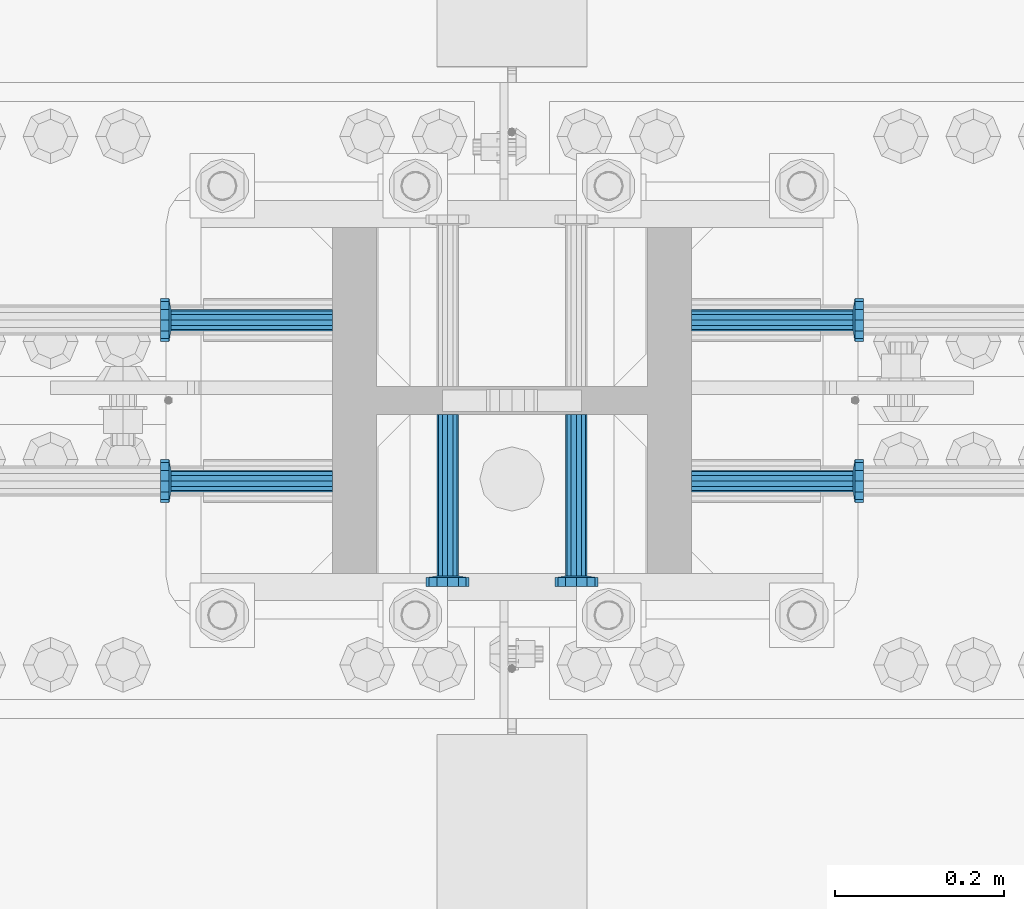
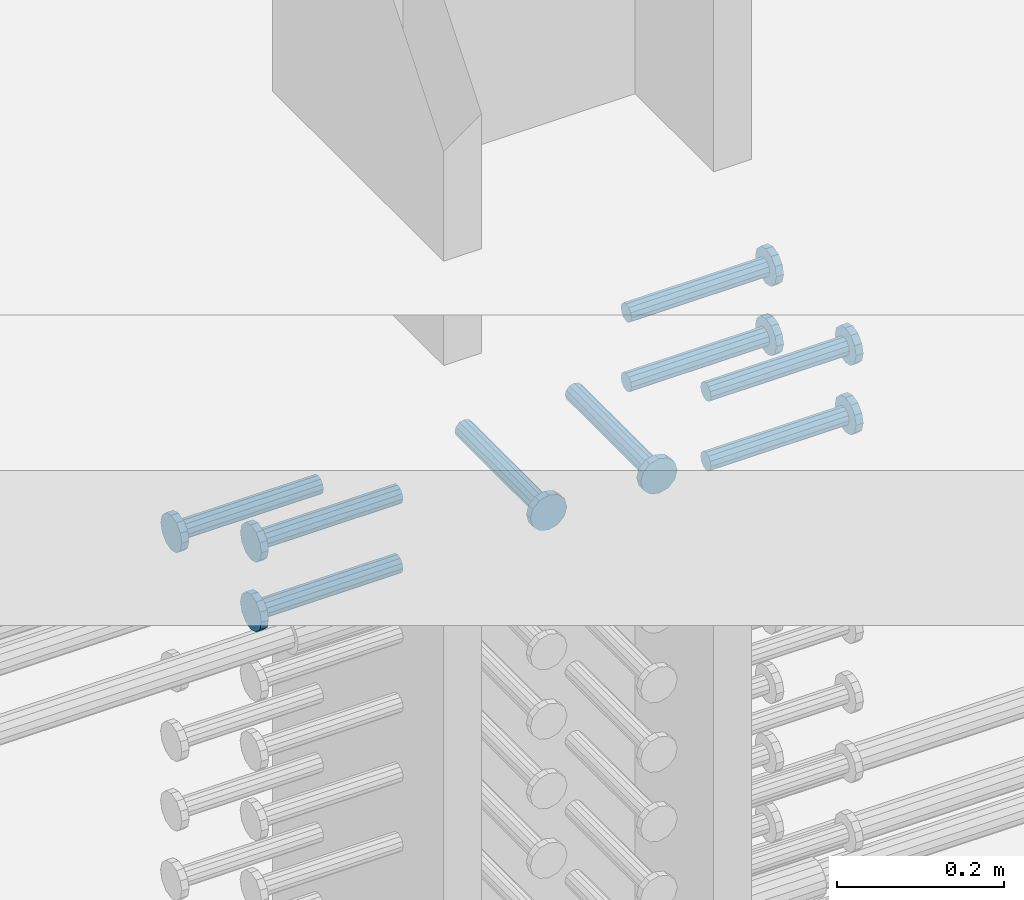
# One storey, part 1216 of 1763: 9 beams, 1 element without a shape of its own.
"""IFC2X3 building model written with IfcOpenShell, lengths in millimetres."""

from ifc_helpers import new_model, si_unit, frame, origin_with_axes, place, context, subcontext, project, spatial, faceted_brep, material, type_object, element, aggregate, save


model = new_model("IFC2X3")

# Units and contexts
model_context = context("Model", 3, precision=1e-05, world=origin_with_axes())
body_context = subcontext(model_context, "Body", "Model", "MODEL_VIEW")
ifc_project = project(units=[si_unit("LENGTHUNIT", "METRE", prefix="MILLI"), si_unit("AREAUNIT", "SQUARE_METRE"), si_unit("VOLUMEUNIT", "CUBIC_METRE"), si_unit("MASSUNIT", "GRAM", prefix="KILO"), si_unit("TIMEUNIT", "SECOND"), si_unit("PLANEANGLEUNIT", "RADIAN"), si_unit("SOLIDANGLEUNIT", "STERADIAN"), si_unit("THERMODYNAMICTEMPERATUREUNIT", "DEGREE_CELSIUS"), si_unit("LUMINOUSINTENSITYUNIT", "LUMEN")], contexts=[model_context])

# Site, building, storey
site_placement = place(None, origin_with_axes())
site = spatial("IfcSite", under=ifc_project, at=site_placement, CompositionType="ELEMENT")
building_placement = place(site_placement, origin_with_axes())
building = spatial("IfcBuilding", under=site, at=building_placement, Name="Undefined", CompositionType="ELEMENT")
storey_placement = place(building_placement, origin_with_axes())
storey = spatial("IfcBuildingStorey", under=building, at=storey_placement, Name="Undefined", CompositionType="ELEMENT", Elevation=0.0)

# Assembly, beams
assembly_placement = place(storey_placement, origin_with_axes())
assembly = element("IfcElementAssembly", 1, at=assembly_placement, inside=storey, Name="COLUMN", AssemblyPlace="NOTDEFINED", PredefinedType="RIGID_FRAME")
ifc_material = material(Name="STEEL/A108")
beam_type = type_object("IfcBeamType", PredefinedType="NOTDEFINED")
beam_1_placement = place(assembly_placement, frame((-61807.1623424341, 361.949999999998, 4927.60000000008), z_axis=(0.0, 1.0, 0.0), x_axis=(-1.0, 0.0, 0.0)))
beam_1 = element("IfcBeam", 2, at=beam_1_placement, type_object=beam_type, material=ifc_material, Name="HEADED STUD ANCHOR", context=body_context, shape_type="Brep", body=[
    faceted_brep([(0.0, -12.6999999999971, -1.81898940354586e-12), (3.63797880709171e-12, -11.0, -6.34999990463257), (191.00799999576, -11.0, -6.34999990454889), (191.007999995752, -12.6999998092651, 8.36735125631094e-11), (7.27595761418343e-12, -6.34999990463257, -11.0), (191.00799999576, -6.34999990463257, -10.9999999999163), (3.63797880709171e-12, 0.0, -12.6999998092651), (191.00799999576, 0.0, -12.6999998091815), (7.27595761418343e-12, 6.34999990463257, -11.0), (191.00799999576, 6.34999990463257, -10.9999999999163), (3.63797880709171e-12, 11.0, -6.34999990463257), (191.00799999576, 11.0, -6.34999990454889), (0.0, 12.6999999999971, -1.81898940354586e-12), (191.007999995752, 12.6999998092651, 8.36735125631094e-11), (0.0, 11.0, 6.34999990463257), (191.007999995752, 11.0, 6.34999990471624), (-3.63797880709171e-12, 6.34999990463257, 11.0), (191.007999995749, 6.34999990463257, 11.0000000000837), (-3.63797880709171e-12, 0.0, 12.6999998092651), (191.007999995749, 0.0, 12.6999998093488), (-3.63797880709171e-12, -6.34999990463257, 11.0), (191.007999995749, -6.34999990463257, 11.0000000000837), (0.0, -11.0, 6.34999990463257), (191.007999995752, -11.0, 6.34999990471624), (193.039999995715, -22.0, -12.6999998091796), (193.039999995708, -25.3999996185303, 8.54925019666553e-11), (193.039999995719, -12.6999998092651, -21.9999999999145), (193.039999995719, 0.0, -25.3999996184448), (193.039999995719, 12.6999998092651, -21.9999999999145), (193.039999995715, 22.0, -12.6999998091796), (193.039999995708, 25.3999996185303, 8.54925019666553e-11), (193.039999995704, 22.0, 12.6999998093506), (193.039999995701, 12.6999998092651, 22.0000000000855), (193.039999995697, 0.0, 25.3999996186158), (193.039999995701, -12.6999998092651, 22.0000000000855), (193.039999995704, -22.0, 12.6999998093506), (203.199999995486, -22.0, -12.6999998091742), (203.199999995482, -25.3999996185303, 9.09494701772928e-11), (203.199999995493, -12.6999998092651, -21.9999999999091), (203.199999995493, 0.0, -25.3999996184393), (203.199999995493, 12.6999998092651, -21.9999999999091), (203.199999995486, 22.0, -12.6999998091742), (203.199999995482, 25.3999996185303, 9.09494701772928e-11), (203.199999995479, 22.0, 12.6999998093561), (203.199999995475, 12.6999998092651, 22.0000000000909), (203.199999995471, 0.0, 25.3999996186212), (203.199999995475, -12.6999998092651, 22.0000000000909), (203.199999995479, -22.0, 12.6999998093561)], [[[0, 1, 2, 3]], [[1, 4, 5, 2]], [[4, 6, 7, 5]], [[6, 8, 9, 7]], [[8, 10, 11, 9]], [[10, 12, 13, 11]], [[12, 14, 15, 13]], [[14, 16, 17, 15]], [[16, 18, 19, 17]], [[18, 20, 21, 19]], [[20, 22, 23, 21]], [[22, 0, 3, 23]], [[22, 20, 18, 16, 14, 12, 10, 8, 6, 4, 1, 0]], [[3, 2, 24, 25]], [[2, 5, 26, 24]], [[5, 7, 27, 26]], [[7, 9, 28, 27]], [[9, 11, 29, 28]], [[11, 13, 30, 29]], [[13, 15, 31, 30]], [[15, 17, 32, 31]], [[17, 19, 33, 32]], [[19, 21, 34, 33]], [[21, 23, 35, 34]], [[23, 3, 25, 35]], [[25, 24, 36, 37]], [[24, 26, 38, 36]], [[26, 27, 39, 38]], [[27, 28, 40, 39]], [[28, 29, 41, 40]], [[29, 30, 42, 41]], [[30, 31, 43, 42]], [[31, 32, 44, 43]], [[32, 33, 45, 44]], [[33, 34, 46, 45]], [[34, 35, 47, 46]], [[35, 25, 37, 47]], [[38, 39, 40, 41, 42, 43, 44, 45, 46, 47, 37, 36]]]),
])
beam_2_placement = place(assembly_placement, frame((-61670.6374108271, 440.53099988573, 4927.60000000008), z_axis=(1.0, 0.0, 0.0), x_axis=(0.0, -1.0, 0.0)))
beam_2 = element("IfcBeam", 3, at=beam_2_placement, type_object=beam_type, material=ifc_material, Name="HEADED STUD ANCHOR", context=body_context, shape_type="Brep", body=[
    faceted_brep([(0.0, -12.6999999999971, -1.81898940354586e-12), (3.63797880709171e-12, -11.0, -6.34999990463257), (191.00799999576, -11.0, -6.34999990454889), (191.007999995752, -12.6999998092651, 8.36735125631094e-11), (7.27595761418343e-12, -6.34999990463257, -11.0), (191.00799999576, -6.34999990463257, -10.9999999999163), (3.63797880709171e-12, 0.0, -12.6999998092651), (191.00799999576, 0.0, -12.6999998091815), (7.27595761418343e-12, 6.34999990463257, -11.0), (191.00799999576, 6.34999990463257, -10.9999999999163), (3.63797880709171e-12, 11.0, -6.34999990463257), (191.00799999576, 11.0, -6.34999990454889), (0.0, 12.6999999999971, -1.81898940354586e-12), (191.007999995752, 12.6999998092651, 8.36735125631094e-11), (0.0, 11.0, 6.34999990463257), (191.007999995752, 11.0, 6.34999990471624), (-3.63797880709171e-12, 6.34999990463257, 11.0), (191.007999995749, 6.34999990463257, 11.0000000000837), (-3.63797880709171e-12, 0.0, 12.6999998092651), (191.007999995749, 0.0, 12.6999998093488), (-3.63797880709171e-12, -6.34999990463257, 11.0), (191.007999995749, -6.34999990463257, 11.0000000000837), (0.0, -11.0, 6.34999990463257), (191.007999995752, -11.0, 6.34999990471624), (193.039999995715, -22.0, -12.6999998091796), (193.039999995708, -25.3999996185303, 8.54925019666553e-11), (193.039999995719, -12.6999998092651, -21.9999999999145), (193.039999995719, 0.0, -25.3999996184448), (193.039999995719, 12.6999998092651, -21.9999999999145), (193.039999995715, 22.0, -12.6999998091796), (193.039999995708, 25.3999996185303, 8.54925019666553e-11), (193.039999995704, 22.0, 12.6999998093506), (193.039999995701, 12.6999998092651, 22.0000000000855), (193.039999995697, 0.0, 25.3999996186158), (193.039999995701, -12.6999998092651, 22.0000000000855), (193.039999995704, -22.0, 12.6999998093506), (203.199999995486, -22.0, -12.6999998091742), (203.199999995482, -25.3999996185303, 9.09494701772928e-11), (203.199999995493, -12.6999998092651, -21.9999999999091), (203.199999995493, 0.0, -25.3999996184393), (203.199999995493, 12.6999998092651, -21.9999999999091), (203.199999995486, 22.0, -12.6999998091742), (203.199999995482, 25.3999996185303, 9.09494701772928e-11), (203.199999995479, 22.0, 12.6999998093561), (203.199999995475, 12.6999998092651, 22.0000000000909), (203.199999995471, 0.0, 25.3999996186212), (203.199999995475, -12.6999998092651, 22.0000000000909), (203.199999995479, -22.0, 12.6999998093561)], [[[0, 1, 2, 3]], [[1, 4, 5, 2]], [[4, 6, 7, 5]], [[6, 8, 9, 7]], [[8, 10, 11, 9]], [[10, 12, 13, 11]], [[12, 14, 15, 13]], [[14, 16, 17, 15]], [[16, 18, 19, 17]], [[18, 20, 21, 19]], [[20, 22, 23, 21]], [[22, 0, 3, 23]], [[22, 20, 18, 16, 14, 12, 10, 8, 6, 4, 1, 0]], [[3, 2, 24, 25]], [[2, 5, 26, 24]], [[5, 7, 27, 26]], [[7, 9, 28, 27]], [[9, 11, 29, 28]], [[11, 13, 30, 29]], [[13, 15, 31, 30]], [[15, 17, 32, 31]], [[17, 19, 33, 32]], [[19, 21, 34, 33]], [[21, 23, 35, 34]], [[23, 3, 25, 35]], [[25, 24, 36, 37]], [[24, 26, 38, 36]], [[26, 27, 39, 38]], [[27, 28, 40, 39]], [[28, 29, 41, 40]], [[29, 30, 42, 41]], [[30, 31, 43, 42]], [[31, 32, 44, 43]], [[32, 33, 45, 44]], [[33, 34, 46, 45]], [[34, 35, 47, 46]], [[35, 25, 37, 47]], [[38, 39, 40, 41, 42, 43, 44, 45, 46, 47, 37, 36]]]),
])
beam_3_placement = place(assembly_placement, frame((-61518.2374108281, 440.531000000006, 4927.60000000008), z_axis=(1.0, 0.0, 0.0), x_axis=(0.0, -1.0, 0.0)))
beam_3 = element("IfcBeam", 4, at=beam_3_placement, type_object=beam_type, material=ifc_material, Name="HEADED STUD ANCHOR", context=body_context, shape_type="Brep", body=[
    faceted_brep([(0.0, -12.6999999999971, -1.81898940354586e-12), (3.63797880709171e-12, -11.0, -6.34999990463257), (191.00799999576, -11.0, -6.34999990454889), (191.007999995752, -12.6999998092651, 8.36735125631094e-11), (7.27595761418343e-12, -6.34999990463257, -11.0), (191.00799999576, -6.34999990463257, -10.9999999999163), (3.63797880709171e-12, 0.0, -12.6999998092651), (191.00799999576, 0.0, -12.6999998091815), (7.27595761418343e-12, 6.34999990463257, -11.0), (191.00799999576, 6.34999990463257, -10.9999999999163), (3.63797880709171e-12, 11.0, -6.34999990463257), (191.00799999576, 11.0, -6.34999990454889), (0.0, 12.6999999999971, -1.81898940354586e-12), (191.007999995752, 12.6999998092651, 8.36735125631094e-11), (0.0, 11.0, 6.34999990463257), (191.007999995752, 11.0, 6.34999990471624), (-3.63797880709171e-12, 6.34999990463257, 11.0), (191.007999995749, 6.34999990463257, 11.0000000000837), (-3.63797880709171e-12, 0.0, 12.6999998092651), (191.007999995749, 0.0, 12.6999998093488), (-3.63797880709171e-12, -6.34999990463257, 11.0), (191.007999995749, -6.34999990463257, 11.0000000000837), (0.0, -11.0, 6.34999990463257), (191.007999995752, -11.0, 6.34999990471624), (193.039999995715, -22.0, -12.6999998091796), (193.039999995708, -25.3999996185303, 8.54925019666553e-11), (193.039999995719, -12.6999998092651, -21.9999999999145), (193.039999995719, 0.0, -25.3999996184448), (193.039999995719, 12.6999998092651, -21.9999999999145), (193.039999995715, 22.0, -12.6999998091796), (193.039999995708, 25.3999996185303, 8.54925019666553e-11), (193.039999995704, 22.0, 12.6999998093506), (193.039999995701, 12.6999998092651, 22.0000000000855), (193.039999995697, 0.0, 25.3999996186158), (193.039999995701, -12.6999998092651, 22.0000000000855), (193.039999995704, -22.0, 12.6999998093506), (203.199999995486, -22.0, -12.6999998091742), (203.199999995482, -25.3999996185303, 9.09494701772928e-11), (203.199999995493, -12.6999998092651, -21.9999999999091), (203.199999995493, 0.0, -25.3999996184393), (203.199999995493, 12.6999998092651, -21.9999999999091), (203.199999995486, 22.0, -12.6999998091742), (203.199999995482, 25.3999996185303, 9.09494701772928e-11), (203.199999995479, 22.0, 12.6999998093561), (203.199999995475, 12.6999998092651, 22.0000000000909), (203.199999995471, 0.0, 25.3999996186212), (203.199999995475, -12.6999998092651, 22.0000000000909), (203.199999995479, -22.0, 12.6999998093561)], [[[0, 1, 2, 3]], [[1, 4, 5, 2]], [[4, 6, 7, 5]], [[6, 8, 9, 7]], [[8, 10, 11, 9]], [[10, 12, 13, 11]], [[12, 14, 15, 13]], [[14, 16, 17, 15]], [[16, 18, 19, 17]], [[18, 20, 21, 19]], [[20, 22, 23, 21]], [[22, 0, 3, 23]], [[22, 20, 18, 16, 14, 12, 10, 8, 6, 4, 1, 0]], [[3, 2, 24, 25]], [[2, 5, 26, 24]], [[5, 7, 27, 26]], [[7, 9, 28, 27]], [[9, 11, 29, 28]], [[11, 13, 30, 29]], [[13, 15, 31, 30]], [[15, 17, 32, 31]], [[17, 19, 33, 32]], [[19, 21, 34, 33]], [[21, 23, 35, 34]], [[23, 3, 25, 35]], [[25, 24, 36, 37]], [[24, 26, 38, 36]], [[26, 27, 39, 38]], [[27, 28, 40, 39]], [[28, 29, 41, 40]], [[29, 30, 42, 41]], [[30, 31, 43, 42]], [[31, 32, 44, 43]], [[32, 33, 45, 44]], [[33, 34, 46, 45]], [[34, 35, 47, 46]], [[35, 25, 37, 47]], [[38, 39, 40, 41, 42, 43, 44, 45, 46, 47, 37, 36]]]),
])
beam_4_placement = place(assembly_placement, frame((-61381.7123897558, 361.950000000609, 4927.60000000008), z_axis=(0.0, 1.0, 0.0), x_axis=(1.0, 0.0, 0.0)))
beam_4 = element("IfcBeam", 5, at=beam_4_placement, type_object=beam_type, material=ifc_material, Name="HEADED STUD ANCHOR", context=body_context, shape_type="Brep", body=[
    faceted_brep([(0.0, -12.6999999999971, -1.81898940354586e-12), (3.63797880709171e-12, -11.0, -6.34999990463257), (191.00799999576, -11.0, -6.34999990454889), (191.007999995752, -12.6999998092651, 8.36735125631094e-11), (7.27595761418343e-12, -6.34999990463257, -11.0), (191.00799999576, -6.34999990463257, -10.9999999999163), (3.63797880709171e-12, 0.0, -12.6999998092651), (191.00799999576, 0.0, -12.6999998091815), (7.27595761418343e-12, 6.34999990463257, -11.0), (191.00799999576, 6.34999990463257, -10.9999999999163), (3.63797880709171e-12, 11.0, -6.34999990463257), (191.00799999576, 11.0, -6.34999990454889), (0.0, 12.6999999999971, -1.81898940354586e-12), (191.007999995752, 12.6999998092651, 8.36735125631094e-11), (0.0, 11.0, 6.34999990463257), (191.007999995752, 11.0, 6.34999990471624), (-3.63797880709171e-12, 6.34999990463257, 11.0), (191.007999995749, 6.34999990463257, 11.0000000000837), (-3.63797880709171e-12, 0.0, 12.6999998092651), (191.007999995749, 0.0, 12.6999998093488), (-3.63797880709171e-12, -6.34999990463257, 11.0), (191.007999995749, -6.34999990463257, 11.0000000000837), (0.0, -11.0, 6.34999990463257), (191.007999995752, -11.0, 6.34999990471624), (193.039999995715, -22.0, -12.6999998091796), (193.039999995708, -25.3999996185303, 8.54925019666553e-11), (193.039999995719, -12.6999998092651, -21.9999999999145), (193.039999995719, 0.0, -25.3999996184448), (193.039999995719, 12.6999998092651, -21.9999999999145), (193.039999995715, 22.0, -12.6999998091796), (193.039999995708, 25.3999996185303, 8.54925019666553e-11), (193.039999995704, 22.0, 12.6999998093506), (193.039999995701, 12.6999998092651, 22.0000000000855), (193.039999995697, 0.0, 25.3999996186158), (193.039999995701, -12.6999998092651, 22.0000000000855), (193.039999995704, -22.0, 12.6999998093506), (203.199999995486, -22.0, -12.6999998091742), (203.199999995482, -25.3999996185303, 9.09494701772928e-11), (203.199999995493, -12.6999998092651, -21.9999999999091), (203.199999995493, 0.0, -25.3999996184393), (203.199999995493, 12.6999998092651, -21.9999999999091), (203.199999995486, 22.0, -12.6999998091742), (203.199999995482, 25.3999996185303, 9.09494701772928e-11), (203.199999995479, 22.0, 12.6999998093561), (203.199999995475, 12.6999998092651, 22.0000000000909), (203.199999995471, 0.0, 25.3999996186212), (203.199999995475, -12.6999998092651, 22.0000000000909), (203.199999995479, -22.0, 12.6999998093561)], [[[0, 1, 2, 3]], [[1, 4, 5, 2]], [[4, 6, 7, 5]], [[6, 8, 9, 7]], [[8, 10, 11, 9]], [[10, 12, 13, 11]], [[12, 14, 15, 13]], [[14, 16, 17, 15]], [[16, 18, 19, 17]], [[18, 20, 21, 19]], [[20, 22, 23, 21]], [[22, 0, 3, 23]], [[22, 20, 18, 16, 14, 12, 10, 8, 6, 4, 1, 0]], [[3, 2, 24, 25]], [[2, 5, 26, 24]], [[5, 7, 27, 26]], [[7, 9, 28, 27]], [[9, 11, 29, 28]], [[11, 13, 30, 29]], [[13, 15, 31, 30]], [[15, 17, 32, 31]], [[17, 19, 33, 32]], [[19, 21, 34, 33]], [[21, 23, 35, 34]], [[23, 3, 25, 35]], [[25, 24, 36, 37]], [[24, 26, 38, 36]], [[26, 27, 39, 38]], [[27, 28, 40, 39]], [[28, 29, 41, 40]], [[29, 30, 42, 41]], [[30, 31, 43, 42]], [[31, 32, 44, 43]], [[32, 33, 45, 44]], [[33, 34, 46, 45]], [[34, 35, 47, 46]], [[35, 25, 37, 47]], [[38, 39, 40, 41, 42, 43, 44, 45, 46, 47, 37, 36]]]),
])
beam_5_placement = place(assembly_placement, frame((-61381.7123210953, 552.449999999998, 4927.60000000008), z_axis=(0.0, 1.0, 0.0), x_axis=(1.0, 0.0, 0.0)))
beam_5 = element("IfcBeam", 6, at=beam_5_placement, type_object=beam_type, material=ifc_material, Name="HEADED STUD ANCHOR", context=body_context, shape_type="Brep", body=[
    faceted_brep([(0.0, -12.6999999999971, -1.81898940354586e-12), (3.63797880709171e-12, -11.0, -6.34999990463257), (191.00799999576, -11.0, -6.34999990454889), (191.007999995752, -12.6999998092651, 8.36735125631094e-11), (7.27595761418343e-12, -6.34999990463257, -11.0), (191.00799999576, -6.34999990463257, -10.9999999999163), (3.63797880709171e-12, 0.0, -12.6999998092651), (191.00799999576, 0.0, -12.6999998091815), (7.27595761418343e-12, 6.34999990463257, -11.0), (191.00799999576, 6.34999990463257, -10.9999999999163), (3.63797880709171e-12, 11.0, -6.34999990463257), (191.00799999576, 11.0, -6.34999990454889), (0.0, 12.6999999999971, -1.81898940354586e-12), (191.007999995752, 12.6999998092651, 8.36735125631094e-11), (0.0, 11.0, 6.34999990463257), (191.007999995752, 11.0, 6.34999990471624), (-3.63797880709171e-12, 6.34999990463257, 11.0), (191.007999995749, 6.34999990463257, 11.0000000000837), (-3.63797880709171e-12, 0.0, 12.6999998092651), (191.007999995749, 0.0, 12.6999998093488), (-3.63797880709171e-12, -6.34999990463257, 11.0), (191.007999995749, -6.34999990463257, 11.0000000000837), (0.0, -11.0, 6.34999990463257), (191.007999995752, -11.0, 6.34999990471624), (193.039999995715, -22.0, -12.6999998091796), (193.039999995708, -25.3999996185303, 8.54925019666553e-11), (193.039999995719, -12.6999998092651, -21.9999999999145), (193.039999995719, 0.0, -25.3999996184448), (193.039999995719, 12.6999998092651, -21.9999999999145), (193.039999995715, 22.0, -12.6999998091796), (193.039999995708, 25.3999996185303, 8.54925019666553e-11), (193.039999995704, 22.0, 12.6999998093506), (193.039999995701, 12.6999998092651, 22.0000000000855), (193.039999995697, 0.0, 25.3999996186158), (193.039999995701, -12.6999998092651, 22.0000000000855), (193.039999995704, -22.0, 12.6999998093506), (203.199999995486, -22.0, -12.6999998091742), (203.199999995482, -25.3999996185303, 9.09494701772928e-11), (203.199999995493, -12.6999998092651, -21.9999999999091), (203.199999995493, 0.0, -25.3999996184393), (203.199999995493, 12.6999998092651, -21.9999999999091), (203.199999995486, 22.0, -12.6999998091742), (203.199999995482, 25.3999996185303, 9.09494701772928e-11), (203.199999995479, 22.0, 12.6999998093561), (203.199999995475, 12.6999998092651, 22.0000000000909), (203.199999995471, 0.0, 25.3999996186212), (203.199999995475, -12.6999998092651, 22.0000000000909), (203.199999995479, -22.0, 12.6999998093561)], [[[0, 1, 2, 3]], [[1, 4, 5, 2]], [[4, 6, 7, 5]], [[6, 8, 9, 7]], [[8, 10, 11, 9]], [[10, 12, 13, 11]], [[12, 14, 15, 13]], [[14, 16, 17, 15]], [[16, 18, 19, 17]], [[18, 20, 21, 19]], [[20, 22, 23, 21]], [[22, 0, 3, 23]], [[22, 20, 18, 16, 14, 12, 10, 8, 6, 4, 1, 0]], [[3, 2, 24, 25]], [[2, 5, 26, 24]], [[5, 7, 27, 26]], [[7, 9, 28, 27]], [[9, 11, 29, 28]], [[11, 13, 30, 29]], [[13, 15, 31, 30]], [[15, 17, 32, 31]], [[17, 19, 33, 32]], [[19, 21, 34, 33]], [[21, 23, 35, 34]], [[23, 3, 25, 35]], [[25, 24, 36, 37]], [[24, 26, 38, 36]], [[26, 27, 39, 38]], [[27, 28, 40, 39]], [[28, 29, 41, 40]], [[29, 30, 42, 41]], [[30, 31, 43, 42]], [[31, 32, 44, 43]], [[32, 33, 45, 44]], [[33, 34, 46, 45]], [[34, 35, 47, 46]], [[35, 25, 37, 47]], [[38, 39, 40, 41, 42, 43, 44, 45, 46, 47, 37, 36]]]),
])
beam_6_placement = place(assembly_placement, frame((-61807.1622049631, 552.449999999823, 4826.00000000007), z_axis=(0.0, 1.0, 0.0), x_axis=(-1.0, 0.0, 0.0)))
beam_6 = element("IfcBeam", 7, at=beam_6_placement, type_object=beam_type, material=ifc_material, Name="HEADED STUD ANCHOR", context=body_context, shape_type="Brep", body=[
    faceted_brep([(0.0, -12.6999999999971, -1.81898940354586e-12), (3.63797880709171e-12, -11.0, -6.34999990463257), (191.00799999576, -11.0, -6.34999990454889), (191.007999995752, -12.6999998092651, 8.36735125631094e-11), (7.27595761418343e-12, -6.34999990463257, -11.0), (191.00799999576, -6.34999990463257, -10.9999999999163), (3.63797880709171e-12, 0.0, -12.6999998092651), (191.00799999576, 0.0, -12.6999998091815), (7.27595761418343e-12, 6.34999990463257, -11.0), (191.00799999576, 6.34999990463257, -10.9999999999163), (3.63797880709171e-12, 11.0, -6.34999990463257), (191.00799999576, 11.0, -6.34999990454889), (0.0, 12.6999999999971, -1.81898940354586e-12), (191.007999995752, 12.6999998092651, 8.36735125631094e-11), (0.0, 11.0, 6.34999990463257), (191.007999995752, 11.0, 6.34999990471624), (-3.63797880709171e-12, 6.34999990463257, 11.0), (191.007999995749, 6.34999990463257, 11.0000000000837), (-3.63797880709171e-12, 0.0, 12.6999998092651), (191.007999995749, 0.0, 12.6999998093488), (-3.63797880709171e-12, -6.34999990463257, 11.0), (191.007999995749, -6.34999990463257, 11.0000000000837), (0.0, -11.0, 6.34999990463257), (191.007999995752, -11.0, 6.34999990471624), (193.039999995715, -22.0, -12.6999998091796), (193.039999995708, -25.3999996185303, 8.54925019666553e-11), (193.039999995719, -12.6999998092651, -21.9999999999145), (193.039999995719, 0.0, -25.3999996184448), (193.039999995719, 12.6999998092651, -21.9999999999145), (193.039999995715, 22.0, -12.6999998091796), (193.039999995708, 25.3999996185303, 8.54925019666553e-11), (193.039999995704, 22.0, 12.6999998093506), (193.039999995701, 12.6999998092651, 22.0000000000855), (193.039999995697, 0.0, 25.3999996186158), (193.039999995701, -12.6999998092651, 22.0000000000855), (193.039999995704, -22.0, 12.6999998093506), (203.199999995486, -22.0, -12.6999998091742), (203.199999995482, -25.3999996185303, 9.09494701772928e-11), (203.199999995493, -12.6999998092651, -21.9999999999091), (203.199999995493, 0.0, -25.3999996184393), (203.199999995493, 12.6999998092651, -21.9999999999091), (203.199999995486, 22.0, -12.6999998091742), (203.199999995482, 25.3999996185303, 9.09494701772928e-11), (203.199999995479, 22.0, 12.6999998093561), (203.199999995475, 12.6999998092651, 22.0000000000909), (203.199999995471, 0.0, 25.3999996186212), (203.199999995475, -12.6999998092651, 22.0000000000909), (203.199999995479, -22.0, 12.6999998093561)], [[[0, 1, 2, 3]], [[1, 4, 5, 2]], [[4, 6, 7, 5]], [[6, 8, 9, 7]], [[8, 10, 11, 9]], [[10, 12, 13, 11]], [[12, 14, 15, 13]], [[14, 16, 17, 15]], [[16, 18, 19, 17]], [[18, 20, 21, 19]], [[20, 22, 23, 21]], [[22, 0, 3, 23]], [[22, 20, 18, 16, 14, 12, 10, 8, 6, 4, 1, 0]], [[3, 2, 24, 25]], [[2, 5, 26, 24]], [[5, 7, 27, 26]], [[7, 9, 28, 27]], [[9, 11, 29, 28]], [[11, 13, 30, 29]], [[13, 15, 31, 30]], [[15, 17, 32, 31]], [[17, 19, 33, 32]], [[19, 21, 34, 33]], [[21, 23, 35, 34]], [[23, 3, 25, 35]], [[25, 24, 36, 37]], [[24, 26, 38, 36]], [[26, 27, 39, 38]], [[27, 28, 40, 39]], [[28, 29, 41, 40]], [[29, 30, 42, 41]], [[30, 31, 43, 42]], [[31, 32, 44, 43]], [[32, 33, 45, 44]], [[33, 34, 46, 45]], [[34, 35, 47, 46]], [[35, 25, 37, 47]], [[38, 39, 40, 41, 42, 43, 44, 45, 46, 47, 37, 36]]]),
])
beam_7_placement = place(assembly_placement, frame((-61807.1622736986, 361.949999999998, 4826.00000000007), z_axis=(0.0, 1.0, 0.0), x_axis=(-1.0, 0.0, 0.0)))
beam_7 = element("IfcBeam", 8, at=beam_7_placement, type_object=beam_type, material=ifc_material, Name="HEADED STUD ANCHOR", context=body_context, shape_type="Brep", body=[
    faceted_brep([(0.0, -12.6999999999971, -1.81898940354586e-12), (3.63797880709171e-12, -11.0, -6.34999990463257), (191.00799999576, -11.0, -6.34999990454889), (191.007999995752, -12.6999998092651, 8.36735125631094e-11), (7.27595761418343e-12, -6.34999990463257, -11.0), (191.00799999576, -6.34999990463257, -10.9999999999163), (3.63797880709171e-12, 0.0, -12.6999998092651), (191.00799999576, 0.0, -12.6999998091815), (7.27595761418343e-12, 6.34999990463257, -11.0), (191.00799999576, 6.34999990463257, -10.9999999999163), (3.63797880709171e-12, 11.0, -6.34999990463257), (191.00799999576, 11.0, -6.34999990454889), (0.0, 12.6999999999971, -1.81898940354586e-12), (191.007999995752, 12.6999998092651, 8.36735125631094e-11), (0.0, 11.0, 6.34999990463257), (191.007999995752, 11.0, 6.34999990471624), (-3.63797880709171e-12, 6.34999990463257, 11.0), (191.007999995749, 6.34999990463257, 11.0000000000837), (-3.63797880709171e-12, 0.0, 12.6999998092651), (191.007999995749, 0.0, 12.6999998093488), (-3.63797880709171e-12, -6.34999990463257, 11.0), (191.007999995749, -6.34999990463257, 11.0000000000837), (0.0, -11.0, 6.34999990463257), (191.007999995752, -11.0, 6.34999990471624), (193.039999995715, -22.0, -12.6999998091796), (193.039999995708, -25.3999996185303, 8.54925019666553e-11), (193.039999995719, -12.6999998092651, -21.9999999999145), (193.039999995719, 0.0, -25.3999996184448), (193.039999995719, 12.6999998092651, -21.9999999999145), (193.039999995715, 22.0, -12.6999998091796), (193.039999995708, 25.3999996185303, 8.54925019666553e-11), (193.039999995704, 22.0, 12.6999998093506), (193.039999995701, 12.6999998092651, 22.0000000000855), (193.039999995697, 0.0, 25.3999996186158), (193.039999995701, -12.6999998092651, 22.0000000000855), (193.039999995704, -22.0, 12.6999998093506), (203.199999995486, -22.0, -12.6999998091742), (203.199999995482, -25.3999996185303, 9.09494701772928e-11), (203.199999995493, -12.6999998092651, -21.9999999999091), (203.199999995493, 0.0, -25.3999996184393), (203.199999995493, 12.6999998092651, -21.9999999999091), (203.199999995486, 22.0, -12.6999998091742), (203.199999995482, 25.3999996185303, 9.09494701772928e-11), (203.199999995479, 22.0, 12.6999998093561), (203.199999995475, 12.6999998092651, 22.0000000000909), (203.199999995471, 0.0, 25.3999996186212), (203.199999995475, -12.6999998092651, 22.0000000000909), (203.199999995479, -22.0, 12.6999998093561)], [[[0, 1, 2, 3]], [[1, 4, 5, 2]], [[4, 6, 7, 5]], [[6, 8, 9, 7]], [[8, 10, 11, 9]], [[10, 12, 13, 11]], [[12, 14, 15, 13]], [[14, 16, 17, 15]], [[16, 18, 19, 17]], [[18, 20, 21, 19]], [[20, 22, 23, 21]], [[22, 0, 3, 23]], [[22, 20, 18, 16, 14, 12, 10, 8, 6, 4, 1, 0]], [[3, 2, 24, 25]], [[2, 5, 26, 24]], [[5, 7, 27, 26]], [[7, 9, 28, 27]], [[9, 11, 29, 28]], [[11, 13, 30, 29]], [[13, 15, 31, 30]], [[15, 17, 32, 31]], [[17, 19, 33, 32]], [[19, 21, 34, 33]], [[21, 23, 35, 34]], [[23, 3, 25, 35]], [[25, 24, 36, 37]], [[24, 26, 38, 36]], [[26, 27, 39, 38]], [[27, 28, 40, 39]], [[28, 29, 41, 40]], [[29, 30, 42, 41]], [[30, 31, 43, 42]], [[31, 32, 44, 43]], [[32, 33, 45, 44]], [[33, 34, 46, 45]], [[34, 35, 47, 46]], [[35, 25, 37, 47]], [[38, 39, 40, 41, 42, 43, 44, 45, 46, 47, 37, 36]]]),
])
beam_8_placement = place(assembly_placement, frame((-61381.7123210203, 361.950000000609, 4826.00000000007), z_axis=(0.0, 1.0, 0.0), x_axis=(1.0, 0.0, 0.0)))
beam_8 = element("IfcBeam", 9, at=beam_8_placement, type_object=beam_type, material=ifc_material, Name="HEADED STUD ANCHOR", context=body_context, shape_type="Brep", body=[
    faceted_brep([(0.0, -12.6999999999971, -1.81898940354586e-12), (3.63797880709171e-12, -11.0, -6.34999990463257), (191.00799999576, -11.0, -6.34999990454889), (191.007999995752, -12.6999998092651, 8.36735125631094e-11), (7.27595761418343e-12, -6.34999990463257, -11.0), (191.00799999576, -6.34999990463257, -10.9999999999163), (3.63797880709171e-12, 0.0, -12.6999998092651), (191.00799999576, 0.0, -12.6999998091815), (7.27595761418343e-12, 6.34999990463257, -11.0), (191.00799999576, 6.34999990463257, -10.9999999999163), (3.63797880709171e-12, 11.0, -6.34999990463257), (191.00799999576, 11.0, -6.34999990454889), (0.0, 12.6999999999971, -1.81898940354586e-12), (191.007999995752, 12.6999998092651, 8.36735125631094e-11), (0.0, 11.0, 6.34999990463257), (191.007999995752, 11.0, 6.34999990471624), (-3.63797880709171e-12, 6.34999990463257, 11.0), (191.007999995749, 6.34999990463257, 11.0000000000837), (-3.63797880709171e-12, 0.0, 12.6999998092651), (191.007999995749, 0.0, 12.6999998093488), (-3.63797880709171e-12, -6.34999990463257, 11.0), (191.007999995749, -6.34999990463257, 11.0000000000837), (0.0, -11.0, 6.34999990463257), (191.007999995752, -11.0, 6.34999990471624), (193.039999995715, -22.0, -12.6999998091796), (193.039999995708, -25.3999996185303, 8.54925019666553e-11), (193.039999995719, -12.6999998092651, -21.9999999999145), (193.039999995719, 0.0, -25.3999996184448), (193.039999995719, 12.6999998092651, -21.9999999999145), (193.039999995715, 22.0, -12.6999998091796), (193.039999995708, 25.3999996185303, 8.54925019666553e-11), (193.039999995704, 22.0, 12.6999998093506), (193.039999995701, 12.6999998092651, 22.0000000000855), (193.039999995697, 0.0, 25.3999996186158), (193.039999995701, -12.6999998092651, 22.0000000000855), (193.039999995704, -22.0, 12.6999998093506), (203.199999995486, -22.0, -12.6999998091742), (203.199999995482, -25.3999996185303, 9.09494701772928e-11), (203.199999995493, -12.6999998092651, -21.9999999999091), (203.199999995493, 0.0, -25.3999996184393), (203.199999995493, 12.6999998092651, -21.9999999999091), (203.199999995486, 22.0, -12.6999998091742), (203.199999995482, 25.3999996185303, 9.09494701772928e-11), (203.199999995479, 22.0, 12.6999998093561), (203.199999995475, 12.6999998092651, 22.0000000000909), (203.199999995471, 0.0, 25.3999996186212), (203.199999995475, -12.6999998092651, 22.0000000000909), (203.199999995479, -22.0, 12.6999998093561)], [[[0, 1, 2, 3]], [[1, 4, 5, 2]], [[4, 6, 7, 5]], [[6, 8, 9, 7]], [[8, 10, 11, 9]], [[10, 12, 13, 11]], [[12, 14, 15, 13]], [[14, 16, 17, 15]], [[16, 18, 19, 17]], [[18, 20, 21, 19]], [[20, 22, 23, 21]], [[22, 0, 3, 23]], [[22, 20, 18, 16, 14, 12, 10, 8, 6, 4, 1, 0]], [[3, 2, 24, 25]], [[2, 5, 26, 24]], [[5, 7, 27, 26]], [[7, 9, 28, 27]], [[9, 11, 29, 28]], [[11, 13, 30, 29]], [[13, 15, 31, 30]], [[15, 17, 32, 31]], [[17, 19, 33, 32]], [[19, 21, 34, 33]], [[21, 23, 35, 34]], [[23, 3, 25, 35]], [[25, 24, 36, 37]], [[24, 26, 38, 36]], [[26, 27, 39, 38]], [[27, 28, 40, 39]], [[28, 29, 41, 40]], [[29, 30, 42, 41]], [[30, 31, 43, 42]], [[31, 32, 44, 43]], [[32, 33, 45, 44]], [[33, 34, 46, 45]], [[34, 35, 47, 46]], [[35, 25, 37, 47]], [[38, 39, 40, 41, 42, 43, 44, 45, 46, 47, 37, 36]]]),
])
beam_9_placement = place(assembly_placement, frame((-61381.7122523598, 552.449999999998, 4826.00000000007), z_axis=(0.0, 1.0, 0.0), x_axis=(1.0, 0.0, 0.0)))
beam_9 = element("IfcBeam", 10, at=beam_9_placement, type_object=beam_type, material=ifc_material, Name="HEADED STUD ANCHOR", context=body_context, shape_type="Brep", body=[
    faceted_brep([(0.0, -12.6999999999971, -1.81898940354586e-12), (3.63797880709171e-12, -11.0, -6.34999990463257), (191.00799999576, -11.0, -6.34999990454889), (191.007999995752, -12.6999998092651, 8.36735125631094e-11), (7.27595761418343e-12, -6.34999990463257, -11.0), (191.00799999576, -6.34999990463257, -10.9999999999163), (3.63797880709171e-12, 0.0, -12.6999998092651), (191.00799999576, 0.0, -12.6999998091815), (7.27595761418343e-12, 6.34999990463257, -11.0), (191.00799999576, 6.34999990463257, -10.9999999999163), (3.63797880709171e-12, 11.0, -6.34999990463257), (191.00799999576, 11.0, -6.34999990454889), (0.0, 12.6999999999971, -1.81898940354586e-12), (191.007999995752, 12.6999998092651, 8.36735125631094e-11), (0.0, 11.0, 6.34999990463257), (191.007999995752, 11.0, 6.34999990471624), (-3.63797880709171e-12, 6.34999990463257, 11.0), (191.007999995749, 6.34999990463257, 11.0000000000837), (-3.63797880709171e-12, 0.0, 12.6999998092651), (191.007999995749, 0.0, 12.6999998093488), (-3.63797880709171e-12, -6.34999990463257, 11.0), (191.007999995749, -6.34999990463257, 11.0000000000837), (0.0, -11.0, 6.34999990463257), (191.007999995752, -11.0, 6.34999990471624), (193.039999995715, -22.0, -12.6999998091796), (193.039999995708, -25.3999996185303, 8.54925019666553e-11), (193.039999995719, -12.6999998092651, -21.9999999999145), (193.039999995719, 0.0, -25.3999996184448), (193.039999995719, 12.6999998092651, -21.9999999999145), (193.039999995715, 22.0, -12.6999998091796), (193.039999995708, 25.3999996185303, 8.54925019666553e-11), (193.039999995704, 22.0, 12.6999998093506), (193.039999995701, 12.6999998092651, 22.0000000000855), (193.039999995697, 0.0, 25.3999996186158), (193.039999995701, -12.6999998092651, 22.0000000000855), (193.039999995704, -22.0, 12.6999998093506), (203.199999995486, -22.0, -12.6999998091742), (203.199999995482, -25.3999996185303, 9.09494701772928e-11), (203.199999995493, -12.6999998092651, -21.9999999999091), (203.199999995493, 0.0, -25.3999996184393), (203.199999995493, 12.6999998092651, -21.9999999999091), (203.199999995486, 22.0, -12.6999998091742), (203.199999995482, 25.3999996185303, 9.09494701772928e-11), (203.199999995479, 22.0, 12.6999998093561), (203.199999995475, 12.6999998092651, 22.0000000000909), (203.199999995471, 0.0, 25.3999996186212), (203.199999995475, -12.6999998092651, 22.0000000000909), (203.199999995479, -22.0, 12.6999998093561)], [[[0, 1, 2, 3]], [[1, 4, 5, 2]], [[4, 6, 7, 5]], [[6, 8, 9, 7]], [[8, 10, 11, 9]], [[10, 12, 13, 11]], [[12, 14, 15, 13]], [[14, 16, 17, 15]], [[16, 18, 19, 17]], [[18, 20, 21, 19]], [[20, 22, 23, 21]], [[22, 0, 3, 23]], [[22, 20, 18, 16, 14, 12, 10, 8, 6, 4, 1, 0]], [[3, 2, 24, 25]], [[2, 5, 26, 24]], [[5, 7, 27, 26]], [[7, 9, 28, 27]], [[9, 11, 29, 28]], [[11, 13, 30, 29]], [[13, 15, 31, 30]], [[15, 17, 32, 31]], [[17, 19, 33, 32]], [[19, 21, 34, 33]], [[21, 23, 35, 34]], [[23, 3, 25, 35]], [[25, 24, 36, 37]], [[24, 26, 38, 36]], [[26, 27, 39, 38]], [[27, 28, 40, 39]], [[28, 29, 41, 40]], [[29, 30, 42, 41]], [[30, 31, 43, 42]], [[31, 32, 44, 43]], [[32, 33, 45, 44]], [[33, 34, 46, 45]], [[34, 35, 47, 46]], [[35, 25, 37, 47]], [[38, 39, 40, 41, 42, 43, 44, 45, 46, 47, 37, 36]]]),
])
aggregate(assembly, [beam_1, beam_2, beam_3, beam_4, beam_5, beam_6, beam_7, beam_8, beam_9])

save(model, "model.ifc")
